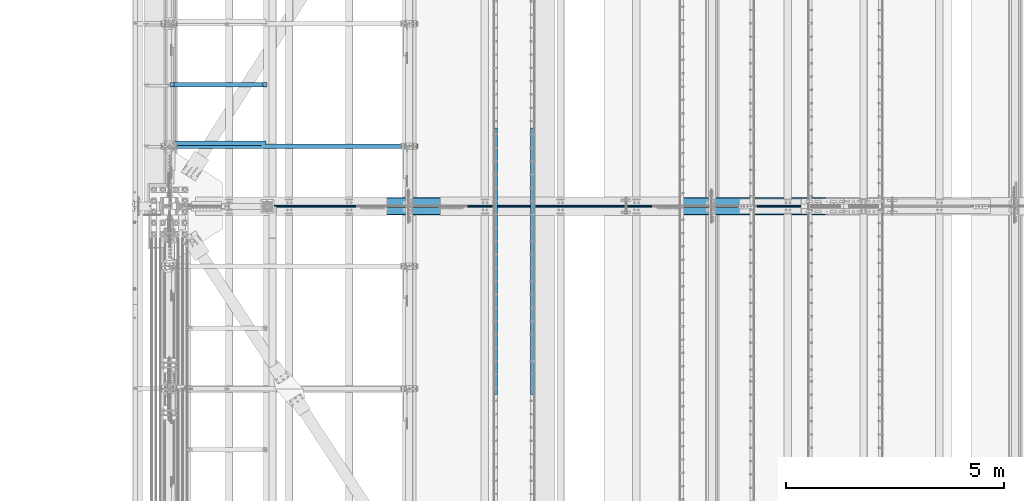
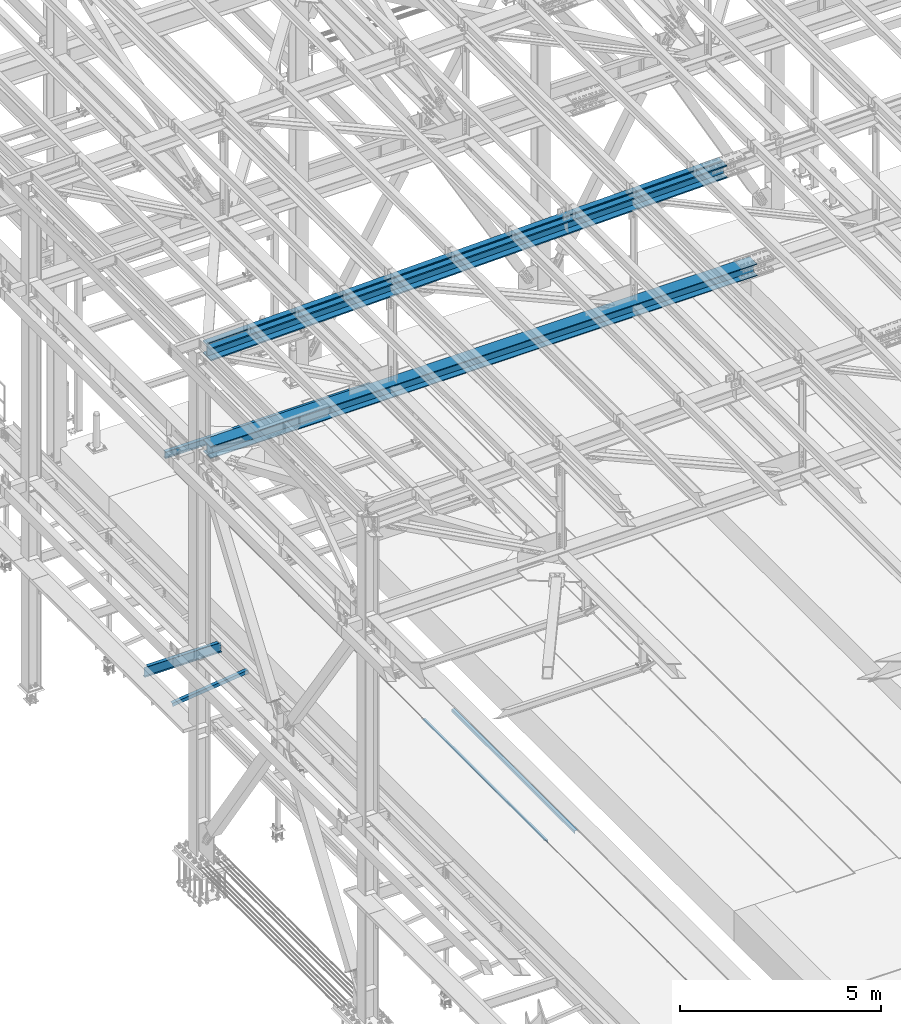
# One storey, part 1874 of 3843: 8 beams, 8 elements without a shape of their own.
"""IFC2X3 building model written with IfcOpenShell, lengths in millimetres."""

from ifc_helpers import new_model, si_unit, frame, origin_with_axes, place, context, subcontext, project, spatial, faceted_brep, material, type_object, element, aggregate, save


model = new_model("IFC2X3")

# Units and contexts
model_context = context("Model", 3, precision=1e-05, world=origin_with_axes())
body_context = subcontext(model_context, "Body", "Model", "MODEL_VIEW")
ifc_project = project(units=[si_unit("LENGTHUNIT", "METRE", prefix="MILLI"), si_unit("AREAUNIT", "SQUARE_METRE"), si_unit("VOLUMEUNIT", "CUBIC_METRE"), si_unit("MASSUNIT", "GRAM", prefix="KILO"), si_unit("TIMEUNIT", "SECOND"), si_unit("PLANEANGLEUNIT", "RADIAN"), si_unit("SOLIDANGLEUNIT", "STERADIAN"), si_unit("THERMODYNAMICTEMPERATUREUNIT", "DEGREE_CELSIUS"), si_unit("LUMINOUSINTENSITYUNIT", "LUMEN")], contexts=[model_context])

# Site, building, storey
site_placement = place(None, origin_with_axes())
site = spatial("IfcSite", under=ifc_project, at=site_placement, CompositionType="ELEMENT")
building_placement = place(site_placement, origin_with_axes())
building = spatial("IfcBuilding", under=site, at=building_placement, Name="Undefined", CompositionType="ELEMENT")
storey_placement = place(building_placement, origin_with_axes())
storey = spatial("IfcBuildingStorey", under=building, at=storey_placement, Name="Undefined", CompositionType="ELEMENT", Elevation=0.0)

# Assembly, beam
assembly_1_placement = place(storey_placement, origin_with_axes())
assembly_1 = element("IfcElementAssembly", 1, at=assembly_1_placement, inside=storey, Name="EMBED_ANGLE", AssemblyPlace="NOTDEFINED", PredefinedType="RIGID_FRAME")
ifc_material_1 = material(Name="STEEL/A36")
beam_type_1 = type_object("IfcBeamType", Name="L3-1/2X3-1/2X5/16", PredefinedType="NOTDEFINED")
beam_1_placement = place(assembly_1_placement, frame((44887.896, 77422.375, 30419.675), z_axis=(0.0, 0.0, -1.0), x_axis=(0.0, -1.0, 0.0)))
beam_1 = element("IfcBeam", 2, at=beam_1_placement, type_object=beam_type_1, material=ifc_material_1, Name="EMBED_ANGLE", ObjectType="L3-1/2X3-1/2X5/16", context=body_context, shape_type="Brep", body=[
    faceted_brep([(-3.63797880709171e-12, 44.4499999999971, -44.4500000000007), (-3.63797880709171e-12, 44.4499999999971, 44.4500000000007), (6096.0, 44.4499999999971, 44.4500000000007), (6096.0, 44.4499999999971, -44.4500000000007), (-3.63797880709171e-12, 36.5124999999971, 44.4500000000007), (6096.0, 36.5124999999971, 44.4500000000007), (-3.63797880709171e-12, 36.5124999999971, -36.5125000000007), (6096.0, 36.5124999999971, -36.5125000000007), (3.63797880709171e-12, -44.4499999999971, -36.5125000000007), (6096.0, -44.4499999999971, -36.5125000000007), (3.63797880709171e-12, -44.4499999999971, -44.4500000000007), (6096.0, -44.4499999999971, -44.4500000000007)], [[[0, 1, 2, 3]], [[1, 4, 5, 2]], [[4, 6, 7, 5]], [[6, 8, 9, 7]], [[8, 10, 11, 9]], [[10, 0, 3, 11]], [[5, 7, 9, 11, 3, 2]], [[10, 8, 6, 4, 1, 0]]]),
])
aggregate(assembly_1, [beam_1])

assembly_2_placement = place(storey_placement, origin_with_axes())
assembly_2 = element("IfcElementAssembly", 3, at=assembly_2_placement, inside=storey, Name="EMBED_ANGLE", AssemblyPlace="NOTDEFINED", PredefinedType="RIGID_FRAME")
beam_2_placement = place(assembly_2_placement, frame((44036.996, 71326.375, 30419.675), z_axis=(0.0, 0.0, -1.0), x_axis=(0.0, 1.0, 0.0)))
beam_2 = element("IfcBeam", 4, at=beam_2_placement, type_object=beam_type_1, material=ifc_material_1, Name="EMBED_ANGLE", ObjectType="L3-1/2X3-1/2X5/16", context=body_context, shape_type="Brep", body=[
    faceted_brep([(-3.63797880709171e-12, 44.4499999999971, -44.4500000000007), (-3.63797880709171e-12, 44.4499999999971, 44.4500000000007), (6096.0, 44.4499999999971, 44.4500000000007), (6096.0, 44.4499999999971, -44.4500000000007), (-3.63797880709171e-12, 36.5124999999971, 44.4500000000007), (6096.0, 36.5124999999971, 44.4500000000007), (-3.63797880709171e-12, 36.5124999999971, -36.5125000000007), (6096.0, 36.5124999999971, -36.5125000000007), (3.63797880709171e-12, -44.4499999999971, -36.5125000000007), (6096.0, -44.4499999999971, -36.5125000000007), (3.63797880709171e-12, -44.4499999999971, -44.4500000000007), (6096.0, -44.4499999999971, -44.4500000000007)], [[[0, 1, 2, 3]], [[1, 4, 5, 2]], [[4, 6, 7, 5]], [[6, 8, 9, 7]], [[8, 10, 11, 9]], [[10, 0, 3, 11]], [[5, 7, 9, 11, 3, 2]], [[10, 8, 6, 4, 1, 0]]]),
])
aggregate(assembly_2, [beam_2])

assembly_3_placement = place(storey_placement, origin_with_axes())
assembly_3 = element("IfcElementAssembly", 5, at=assembly_3_placement, inside=storey, Name="ANGLE", AssemblyPlace="NOTDEFINED", PredefinedType="RIGID_FRAME")
ifc_material_2 = material(Name="STEEL/A572-50")
beam_type_2 = type_object("IfcBeamType", Name="L4X4X3/8", PredefinedType="NOTDEFINED")
beam_3_placement = place(assembly_3_placement, frame((38788.5093206542, 77075.208594, 33960.1419503901), z_axis=(0.0, 1.0, 0.0), x_axis=(-0.993268693078032, 0.0, -0.115833084009098)))
beam_3 = element("IfcBeam", 6, at=beam_3_placement, type_object=beam_type_2, material=ifc_material_2, Name="ANGLE", ObjectType="L4X4X3/8", context=body_context, shape_type="Brep", body=[
    faceted_brep([(0.0, 50.8000000000029, -50.8000000000029), (0.0, 50.8000000000029, 50.8000000000029), (2192.8104802954, 50.7999999940694, 50.8000000000029), (2192.8104802954, 50.7999999940694, -50.8000000000029), (0.0, 41.2750000000015, 50.8000000000029), (2192.81048029537, 41.2749999940788, 50.8000000000029), (0.0, 41.2749999999942, -41.2750000000015), (2192.81048029537, 41.2749999940788, -41.2750000000015), (0.0, -50.8000000000029, -41.2750000000015), (2192.81048029512, -50.8000000058528, -41.2750000000015), (0.0, -50.8000000000029, -50.8000000000029), (2192.81048029512, -50.8000000058528, -50.8000000000029)], [[[0, 1, 2, 3]], [[1, 4, 5, 2]], [[4, 6, 7, 5]], [[6, 8, 9, 7]], [[8, 10, 11, 9]], [[10, 0, 3, 11]], [[5, 7, 9, 11, 3, 2]], [[10, 8, 6, 4, 1, 0]]]),
])
aggregate(assembly_3, [beam_3])

assembly_4_placement = place(storey_placement, origin_with_axes())
assembly_4 = element("IfcElementAssembly", 7, at=assembly_4_placement, inside=storey, Name="dummy", AssemblyPlace="NOTDEFINED", PredefinedType="RIGID_FRAME")
ifc_material_3 = material(Name="STEEL/A992")
beam_type_3 = type_object("IfcBeamType", PredefinedType="NOTDEFINED")
beam_4_placement = place(assembly_4_placement, frame((36788.7250000008, 75628.5, 45423.9652363506), z_axis=(-0.0250987889943571, 0.0, 0.999684975775377), x_axis=(0.999684975775377, 0.0, 0.0250987889943604)))
beam_4 = element("IfcBeam", 8, at=beam_4_placement, type_object=beam_type_3, material=ifc_material_3, Name="dummy", context=body_context, shape_type="Brep", body=[
    faceted_brep([(0.0, -24.6059999999998, 0.0), (0.0, -21.3094210855197, -12.3029999999999), (14796.986409431, -21.3094210855197, -12.3029999777136), (14796.9864094309, -24.6059999999998, 2.22644302994013e-08), (0.0, -12.3029999999999, -21.3094210855197), (14796.986409431, -12.3029999999999, -21.3094210632116), (0.0, 0.0, -24.6059999999998), (14796.986409431, 0.0, -24.6059999776917), (0.0, 12.3029999999999, -21.3094210855197), (14796.986409431, 12.3029999999999, -21.3094210632116), (0.0, 21.3094210855197, -12.3029999999999), (14796.986409431, 21.3094210855197, -12.3029999777136), (0.0, 24.6059999999998, 0.0), (14796.9864094309, 24.6059999999998, 2.22644302994013e-08), (0.0, 21.3094210855197, 12.3029999999999), (14796.9864094309, 21.3094210855197, 12.3030000222425), (0.0, 12.3029999999999, 21.3094210855197), (14796.9864094309, 12.3029999999999, 21.3094211077478), (0.0, 0.0, 24.6059999999998), (14796.9864094309, 0.0, 24.6060000222205), (0.0, -12.3029999999999, 21.3094210855197), (14796.9864094309, -12.3029999999999, 21.3094211077478), (0.0, -21.3094210855197, 12.3029999999999), (14796.9864094309, -21.3094210855197, 12.3030000222425)], [[[0, 1, 2, 3]], [[1, 4, 5, 2]], [[4, 6, 7, 5]], [[6, 8, 9, 7]], [[8, 10, 11, 9]], [[10, 12, 13, 11]], [[12, 14, 15, 13]], [[14, 16, 17, 15]], [[16, 18, 19, 17]], [[18, 20, 21, 19]], [[20, 22, 23, 21]], [[22, 0, 3, 23]], [[5, 7, 9, 11, 13, 15, 17, 19, 21, 23, 3, 2]], [[22, 20, 18, 16, 14, 12, 10, 8, 6, 4, 1, 0]]]),
])
aggregate(assembly_4, [beam_4])

assembly_5_placement = place(storey_placement, origin_with_axes())
assembly_5 = element("IfcElementAssembly", 9, at=assembly_5_placement, inside=storey, Name="BEAM", AssemblyPlace="NOTDEFINED", PredefinedType="RIGID_FRAME")
beam_type_4 = type_object("IfcBeamType", Name="W8X13", PredefinedType="NOTDEFINED")
beam_5_placement = place(assembly_5_placement, frame((36372.8, 77000.1, 41402.0), z_axis=(0.0, 0.0, 1.0), x_axis=(1.0, 0.0, 0.0)))
beam_5 = element("IfcBeam", 10, at=beam_5_placement, type_object=beam_type_4, material=ifc_material_3, Name="BEAM", ObjectType="W8X13", context=body_context, shape_type="Brep", body=[
    faceted_brep([(0.0, 50.7999999999993, -101.599999999999), (0.0, 50.7999999999993, -95.25), (5892.8, 50.7999999999993, -95.25), (5892.8, 50.7999999999993, -101.599999999999), (0.0, 3.17499999999927, -95.25), (5892.8, 3.17499999999927, -95.25), (-2.44140610448085e-05, 3.17500000000291, 95.2499999999927), (5892.8, 3.17499999999927, 95.25), (0.0, 50.7999999999993, 95.25), (5892.8, 50.7999999999993, 95.25), (0.0, 50.7999999999993, 101.599999999999), (5892.8, 50.7999999999993, 101.599999999999), (0.0, -50.7999999999993, 101.599999999999), (5892.8, -50.7999999999993, 101.599999999999), (0.0, -50.7999999999993, 95.25), (5892.8, -50.7999999999993, 95.25), (0.0, -3.17499999999927, 95.25), (5892.8, -3.17499999999927, 95.25), (0.0, -3.17499999999927, -95.25), (5892.8, -3.17499999999927, -95.25), (0.0, -50.7999999999993, -95.25), (5892.8, -50.7999999999993, -95.25), (0.0, -50.7999999999993, -101.599999999999), (5892.8, -50.7999999999993, -101.599999999999)], [[[0, 1, 2, 3]], [[1, 4, 5, 2]], [[4, 6, 7, 5]], [[6, 8, 9, 7]], [[8, 10, 11, 9]], [[10, 12, 13, 11]], [[12, 14, 15, 13]], [[14, 16, 17, 15]], [[16, 18, 19, 17]], [[18, 20, 21, 19]], [[20, 22, 23, 21]], [[22, 0, 3, 23]], [[5, 7, 9, 11, 13, 15, 17, 19, 21, 23, 3, 2]], [[22, 20, 18, 16, 14, 12, 10, 8, 6, 4, 1, 0]]]),
])
aggregate(assembly_5, [beam_5])

assembly_6_placement = place(storey_placement, origin_with_axes())
assembly_6 = element("IfcElementAssembly", 11, at=assembly_6_placement, inside=storey, Name="BEAM", AssemblyPlace="NOTDEFINED", PredefinedType="RIGID_FRAME")
beam_type_5 = type_object("IfcBeamType", Name="W14X193", PredefinedType="NOTDEFINED")
beam_6_placement = place(assembly_6_placement, frame((36581.1928042774, 75628.5, 45221.5968555615), z_axis=(-0.0251104770065213, 0.0, 0.999684682259614), x_axis=(0.99968468698203, 0.0, 0.0251102889995484)))
beam_6 = element("IfcBeam", 12, at=beam_6_placement, type_object=beam_type_5, material=ifc_material_3, Name="BEAM", ObjectType="W14X193", context=body_context, shape_type="Brep", body=[
    faceted_brep([(12012.6310230838, 11.1125000000029, 163.391995248145), (12012.6310230838, 200.024999999994, 163.391995248145), (13514.235091335, 200.024999999994, 162.055596819482), (13514.235091335, 11.1125000000029, 162.055596819482), (10511.0266180469, 11.1125000000029, 164.346565542677), (10511.0266180469, 200.025000000001, 164.346565542677), (9009.42207084113, 11.1125000000029, 164.919307789831), (9009.42207084113, 200.025000000001, 164.919307789831), (7507.81742654402, 11.1125000000029, 165.110221879142), (7507.81742654402, 200.025000000001, 165.110221879142), (6006.21278224691, 11.1125000000029, 164.919307800374), (6006.21278224691, 200.025000000001, 164.919307800374), (4504.60823504109, 11.1125000000029, 164.346565563763), (4504.60823504109, 200.025000000001, 164.346565563763), (3003.00388201789, 11.1125000000029, 163.391995209349), (3003.00388201789, 200.025000000001, 163.391995209349), (1501.39982026855, 11.1125000000029, 162.055596795835), (1501.39982026855, 200.025000000001, 162.055596795835), (211.63116127815, 11.1125000000029, 160.579764938106), (211.63116127815, 200.024999999994, 160.579764938106), (12012.3863993012, 200.024999999994, -157.282911447997), (12012.3863993012, 11.1125000000029, -157.282911447997), (13513.9089263161, 11.1125000000029, -158.619237306542), (13513.9089263161, 200.024999999994, -158.619237306542), (10510.8635355159, 200.025000000001, -156.328392989126), (10510.8635355159, 11.1125000000029, -156.328392989126), (9009.34052957242, 200.025000000001, -155.75568184346), (9009.34052957242, 11.1125000000029, -155.75568184346), (7507.8174265429, 200.025000000001, -155.564778121312), (7507.8174265429, 11.1125000000029, -155.564778121312), (6006.29432351337, 200.025000000001, -155.755681832918), (6006.29432351337, 11.1125000000029, -155.755681832918), (4504.77131756986, 200.025000000001, -156.328392968047), (4504.77131756986, 11.1125000000029, -156.328392968047), (3003.24850579841, 200.025000000001, -157.282911486654), (3003.24850579841, 11.1125000000029, -157.282911486654), (1501.72598528501, 200.025000000001, -158.619237330058), (1501.72598528501, 11.1125000000029, -158.619237330058), (203.576082502259, 200.024999999994, -160.104659517652), (203.576082502259, 11.1125000000029, -160.104659517652), (12012.3585460982, -200.024999999994, -193.795400824296), (12012.3585460982, 200.024999999994, -193.795400824296), (13513.8717887149, 200.024999999994, -195.1317184199), (13513.8717887149, -200.024999999994, -195.1317184199), (10510.8449667129, -200.025000000001, -192.840888267507), (10510.8449667129, 200.025000000001, -192.840888267507), (9009.33124517055, -200.025000000001, -192.268180663086), (9009.33124517055, 200.025000000001, -192.268180663086), (7507.81742654277, -200.025000000001, -192.07727812136), (7507.81742654277, 200.025000000001, -192.07727812136), (6006.303607915, -200.025000000001, -192.268180652551), (6006.303607915, 200.025000000001, -192.268180652551), (4504.78988637264, -200.025000000001, -192.840888246428), (4504.78988637264, 200.025000000001, -192.840888246428), (3003.27635900114, -200.025000000001, -193.795400862931), (3003.27635900114, 200.025000000001, -193.795400862931), (1501.7631228859, -200.025000000001, -195.131718443416), (1501.7631228859, 200.025000000001, -195.131718443416), (202.658920067377, -200.024999999994, -196.618232599249), (202.658920067377, 200.024999999994, -196.618232599249), (12012.3863993012, -11.1125000000029, -157.282911447997), (12012.3863993012, -200.024999999994, -157.282911447997), (13513.9089263161, -200.024999999994, -158.619237306542), (13513.9089263161, -11.1125000000029, -158.619237306542), (10510.8635355159, -11.1125000000029, -156.328392989126), (10510.8635355159, -200.025000000001, -156.328392989126), (9009.34052957242, -11.1125000000029, -155.75568184346), (9009.34052957242, -200.025000000001, -155.75568184346), (7507.8174265429, -11.1125000000029, -155.564778121312), (7507.8174265429, -200.025000000001, -155.564778121312), (6006.29432351337, -11.1125000000029, -155.755681832918), (6006.29432351337, -200.025000000001, -155.755681832918), (4504.77131756986, -11.1125000000029, -156.328392968047), (4504.77131756986, -200.025000000001, -156.328392968047), (3003.24850579841, -11.1125000000029, -157.282911486654), (3003.24850579841, -200.025000000001, -157.282911486654), (1501.72598528501, -11.1125000000029, -158.619237330058), (1501.72598528501, -200.025000000001, -158.619237330058), (203.576082502259, -11.1125000000029, -160.104659517652), (203.576082502259, -200.024999999994, -160.104659517652), (12012.6310230838, -200.024999999994, 163.391995248145), (12012.6310230838, -11.1125000000029, 163.391995248145), (13514.235091335, -11.1125000000029, 162.055596819482), (13514.235091335, -200.024999999994, 162.055596819482), (10511.0266180469, -200.025000000001, 164.346565542677), (10511.0266180469, -11.1125000000029, 164.346565542677), (9009.42207084113, -200.025000000001, 164.919307789831), (9009.42207084113, -11.1125000000029, 164.919307789831), (7507.81742654402, -200.025000000001, 165.110221879142), (7507.81742654402, -11.1125000000029, 165.110221879142), (6006.21278224691, -200.025000000001, 164.919307800374), (6006.21278224691, -11.1125000000029, 164.919307800374), (4504.60823504109, -200.025000000001, 164.346565563763), (4504.60823504109, -11.1125000000029, 164.346565563763), (3003.00388201789, -200.025000000001, 163.391995209349), (3003.00388201789, -11.1125000000029, 163.391995209349), (1501.39982026855, -200.025000000001, 162.055596795835), (1501.39982026855, -11.1125000000029, 162.055596795835), (211.63116127815, -200.024999999994, 160.579764938106), (211.63116127815, -11.1125000000029, 160.579764938106), (212.548323713025, -200.024999999994, 197.093338019702), (212.548323713025, 200.024999999994, 197.093338019702), (1501.36268266766, -200.025000000001, 198.568077909178), (1501.36268266766, 200.025000000001, 198.568077909178), (3002.97602881516, -200.025000000001, 199.904484585633), (3002.97602881516, 200.025000000001, 199.904484585633), (4504.58966623832, -200.025000000001, 200.859060842136), (4504.58966623832, 200.025000000001, 200.859060842136), (6006.20349784529, -200.025000000001, 201.431806620007), (6006.20349784529, 200.025000000001, 201.431806620007), (7507.81742654416, -200.025000000001, 201.622721879205), (7507.81742654416, 200.025000000001, 201.622721879205), (9009.43135524302, -200.025000000001, 201.431806609464), (9009.43135524302, 200.025000000001, 201.431806609464), (10511.04518685, -200.025000000001, 200.859060821043), (10511.04518685, 200.025000000001, 200.859060821043), (12012.6588762868, -200.024999999994, 199.904484624436), (12012.6588762868, 200.024999999994, 199.904484624436), (13514.2722289362, -200.024999999994, 198.56807793284), (13514.2722289362, 200.024999999994, 198.56807793284), (15009.5351971531, -200.024999999994, 196.857106955591), (15009.5351971531, 200.024999999994, 196.857106955591), (15009.4888100907, 200.024999999994, 160.344636426023), (15009.4888100907, 11.1125000000029, 160.344636426023), (15009.0814342832, 11.1125000000029, -160.33010490358), (15009.0814342832, 200.025000000001, -160.33010490358), (15009.0350562786, 200.025000000001, -196.842575443494), (15009.0350562786, -200.025000000001, -196.842575443494), (15009.0814342832, -200.025000000001, -160.33010490358), (15009.0814342832, -11.1125000000029, -160.33010490358), (15009.4888100907, -11.1125000000029, 160.344636426023), (15009.4888100907, -200.024999999994, 160.344636426023)], [[[0, 1, 2, 3]], [[4, 5, 1, 0]], [[6, 7, 5, 4]], [[8, 9, 7, 6]], [[10, 11, 9, 8]], [[12, 13, 11, 10]], [[14, 15, 13, 12]], [[16, 17, 15, 14]], [[17, 16, 18, 19]], [[20, 21, 22, 23]], [[24, 25, 21, 20]], [[26, 27, 25, 24]], [[28, 29, 27, 26]], [[30, 31, 29, 28]], [[32, 33, 31, 30]], [[34, 35, 33, 32]], [[36, 37, 35, 34]], [[37, 36, 38, 39]], [[40, 41, 42, 43]], [[44, 45, 41, 40]], [[46, 47, 45, 44]], [[48, 49, 47, 46]], [[50, 51, 49, 48]], [[52, 53, 51, 50]], [[54, 55, 53, 52]], [[56, 57, 55, 54]], [[57, 56, 58, 59]], [[60, 61, 62, 63]], [[64, 65, 61, 60]], [[66, 67, 65, 64]], [[68, 69, 67, 66]], [[70, 71, 69, 68]], [[72, 73, 71, 70]], [[74, 75, 73, 72]], [[76, 77, 75, 74]], [[77, 76, 78, 79]], [[80, 81, 82, 83]], [[84, 85, 81, 80]], [[86, 87, 85, 84]], [[88, 89, 87, 86]], [[90, 91, 89, 88]], [[92, 93, 91, 90]], [[94, 95, 93, 92]], [[96, 97, 95, 94]], [[97, 96, 98, 99]], [[19, 18, 39, 38, 59, 58, 79, 78, 99, 98, 100, 101]], [[102, 103, 101, 100]], [[103, 102, 104, 105]], [[105, 104, 106, 107]], [[107, 106, 108, 109]], [[109, 108, 110, 111]], [[111, 110, 112, 113]], [[113, 112, 114, 115]], [[115, 114, 116, 117]], [[117, 116, 118, 119]], [[119, 118, 120, 121]], [[2, 1, 5, 7, 9, 11, 13, 15, 17, 19, 101, 103, 105, 107, 109, 111, 113, 115, 117, 119, 121, 122]], [[3, 2, 122, 123]], [[22, 21, 25, 27, 29, 31, 33, 35, 37, 39, 18, 16, 14, 12, 10, 8, 6, 4, 0, 3, 123, 124]], [[23, 22, 124, 125]], [[42, 41, 45, 47, 49, 51, 53, 55, 57, 59, 38, 36, 34, 32, 30, 28, 26, 24, 20, 23, 125, 126]], [[43, 42, 126, 127]], [[62, 61, 65, 67, 69, 71, 73, 75, 77, 79, 58, 56, 54, 52, 50, 48, 46, 44, 40, 43, 127, 128]], [[63, 62, 128, 129]], [[82, 81, 85, 87, 89, 91, 93, 95, 97, 99, 78, 76, 74, 72, 70, 68, 66, 64, 60, 63, 129, 130]], [[83, 82, 130, 131]], [[118, 116, 114, 112, 110, 108, 106, 104, 102, 100, 98, 96, 94, 92, 90, 88, 86, 84, 80, 83, 131, 120]], [[130, 129, 128, 127, 126, 125, 124, 123, 122, 121, 120, 131]]]),
])
aggregate(assembly_6, [beam_6])

assembly_7_placement = place(storey_placement, origin_with_axes())
assembly_7 = element("IfcElementAssembly", 13, at=assembly_7_placement, inside=storey, Name="BEAM", AssemblyPlace="NOTDEFINED", PredefinedType="RIGID_FRAME")
beam_type_6 = type_object("IfcBeamType", Name="W14X120", PredefinedType="NOTDEFINED")
beam_7_placement = place(assembly_7_placement, frame((36575.995336456, 75628.5, 42246.5516278841), z_axis=(-0.00388797399922624, 0.0, 0.999992441800527), x_axis=(0.999992441800527, 0.0, 0.0038879739992243)))
beam_7 = element("IfcBeam", 14, at=beam_7_placement, type_object=beam_type_6, material=ifc_material_3, Name="BEAM", ObjectType="W14X120", context=body_context, shape_type="Brep", body=[
    faceted_brep([(9532.73839779652, -185.737500000003, 165.469169509452), (9532.73839779652, -7.14375000000291, 165.469169509452), (11121.5643632774, -7.14375000000291, 164.827692591709), (11121.5643632774, -185.737500000003, 164.827692591709), (7943.91231720828, -185.737500000003, 165.682995153409), (7943.91231720828, -7.14375000000291, 165.682995153409), (6355.08623662005, -185.737500000003, 165.469169506832), (6355.08623662005, -7.14375000000291, 165.469169506832), (4766.2602711392, -185.737500000003, 164.827692586485), (4766.2602711392, -7.14375000000291, 164.827692586485), (3177.43453587312, -185.737500000003, 163.758564437994), (3177.43453587312, -7.14375000000291, 163.758564437994), (1588.60914592918, -185.737500000003, 162.261785139592), (1588.60914592918, -7.14375000000291, 162.261785139592), (213.479540827058, -185.737500000003, 160.596188706673), (213.479540827058, -7.14375000000291, 160.596188706673), (12710.3900985434, 7.14375000000291, 163.75856444583), (12710.3900985434, 185.737500000003, 163.75856444583), (14299.2154884874, 185.737500000003, 162.261785150054), (14299.2154884874, 7.14375000000291, 162.261785150054), (11121.5643632774, 7.14375000000291, 164.827692591709), (11121.5643632774, 185.737500000003, 164.827692591709), (9532.73839779652, 7.14375000000291, 165.469169509452), (9532.73839779652, 185.737500000003, 165.469169509452), (7943.91231720828, 7.14375000000291, 165.682995153409), (7943.91231720828, 185.737500000003, 165.682995153409), (6355.08623662005, 7.14375000000291, 165.469169506832), (6355.08623662005, 185.737500000003, 165.469169506832), (4766.2602711392, 7.14375000000291, 164.827692586485), (4766.2602711392, 185.737500000003, 164.827692586485), (3177.43453587312, 7.14375000000291, 163.758564437994), (3177.43453587312, 185.737500000003, 163.758564437994), (1588.60914592918, 7.14375000000291, 162.261785139592), (1588.60914592918, 185.737500000003, 162.261785139592), (213.479540827058, 7.14375000000291, 160.596188706673), (213.479540827058, 185.737500000003, 160.596188706673), (12710.1311581915, 185.737500000003, -156.916331009219), (12710.1311581915, 7.14375000000291, -156.916331009219), (14298.8702347139, 7.14375000000291, -158.413028992014), (14298.8702347139, 185.737500000003, -158.413028992014), (11121.3917363657, 185.737500000003, -155.847260944051), (11121.3917363657, 7.14375000000291, -155.847260944051), (9532.65208433771, 185.737500000003, -155.205818874747), (9532.65208433771, 7.14375000000291, -155.205818874747), (7943.91231720855, 185.737500000003, -154.992004846928), (7943.91231720855, 7.14375000000291, -154.992004846928), (6355.17255007938, 185.737500000003, -155.205818877366), (6355.17255007938, 7.14375000000291, -155.205818877366), (4766.43289805136, 185.737500000003, -155.847260949289), (4766.43289805136, 7.14375000000291, -155.847260949289), (3177.69347622558, 185.737500000003, -156.91633101707), (3177.69347622558, 7.14375000000291, -156.91633101707), (1588.95439970319, 185.737500000003, -158.41302900247), (1588.95439970319, 7.14375000000291, -158.41302900247), (213.900240854979, 185.737500000003, -160.078534052729), (213.900240854979, 7.14375000000291, -160.078534052729), (12710.1119299476, -185.737500000003, -180.728823245983), (12710.1119299476, 185.737500000003, -180.728823245983), (14298.8445970575, 185.737500000003, -182.225515190672), (14298.8445970575, -185.737500000003, -182.225515190672), (11121.3789175357, -185.737500000003, -179.65975749374), (11121.3789175357, 185.737500000003, -179.65975749374), (9532.64567492246, -185.737500000003, -179.018318012182), (9532.64567492246, 185.737500000003, -179.018318012182), (7943.91231720857, -185.737500000003, -178.804504846958), (7943.91231720857, 185.737500000003, -178.804504846958), (6355.17895949468, -185.737500000003, -179.018318014801), (6355.17895949468, 185.737500000003, -179.018318014801), (4766.44571688146, -185.737500000003, -179.659757498965), (4766.44571688146, 185.737500000003, -179.659757498965), (3177.71270446959, -185.737500000003, -180.728823253827), (3177.71270446959, 185.737500000003, -180.728823253827), (1588.98003735969, -185.737500000003, -182.225515201142), (1588.98003735969, 185.737500000003, -182.225515201142), (213.93148095606, -185.737500000003, -183.891013465553), (213.93148095606, 185.737500000003, -183.891013465553), (12710.1311581915, -7.14375000000291, -156.916331009219), (12710.1311581915, -185.737500000003, -156.916331009219), (14298.8702347139, -185.737500000003, -158.413028992014), (14298.8702347139, -7.14375000000291, -158.413028992014), (11121.3917363657, -7.14375000000291, -155.847260944051), (11121.3917363657, -185.737500000003, -155.847260944051), (9532.65208433771, -7.14375000000291, -155.205818874747), (9532.65208433771, -185.737500000003, -155.205818874747), (7943.91231720855, -7.14375000000291, -154.992004846928), (7943.91231720855, -185.737500000003, -154.992004846928), (6355.17255007938, -7.14375000000291, -155.205818877366), (6355.17255007938, -185.737500000003, -155.205818877366), (4766.43289805136, -7.14375000000291, -155.847260949289), (4766.43289805136, -185.737500000003, -155.847260949289), (3177.69347622558, -7.14375000000291, -156.91633101707), (3177.69347622558, -185.737500000003, -156.91633101707), (1588.95439970319, -7.14375000000291, -158.41302900247), (1588.95439970319, -185.737500000003, -158.41302900247), (213.900240854979, -7.14375000000291, -160.078534052729), (213.900240854979, -185.737500000003, -160.078534052729), (213.448300725977, -185.737500000003, 184.408668119504), (213.448300725977, 185.737500000003, 184.408668119504), (1588.5835082727, -185.737500000003, 186.074271338264), (1588.5835082727, 185.737500000003, 186.074271338264), (3177.41530762913, -185.737500000003, 187.571056674751), (3177.41530762913, 185.737500000003, 187.571056674751), (4766.24745230909, -185.737500000003, 188.640189136167), (4766.24745230909, 185.737500000003, 188.640189136167), (6355.07982720475, -185.737500000003, 189.281668644275), (6355.07982720475, 185.737500000003, 189.281668644275), (7943.91231720826, -185.737500000003, 189.495495153438), (7943.91231720826, 185.737500000003, 189.495495153438), (9532.74480721178, -185.737500000003, 189.281668646887), (9532.74480721178, 185.737500000003, 189.281668646887), (11121.5771821074, -185.737500000003, 188.640189141399), (11121.5771821074, 185.737500000003, 188.640189141399), (12710.4093267874, -185.737500000003, 187.571056682595), (12710.4093267874, 185.737500000003, 187.571056682595), (14299.2411261438, -185.737500000003, 186.074271348727), (14299.2411261438, 185.737500000003, 186.074271348727), (15881.7223570669, -185.737500000003, 184.157524679875), (15881.7223570669, 185.737500000003, 184.157524679875), (15881.6903245479, 185.737500000003, 160.345046226852), (15881.6903245479, 7.14375000000291, 160.345046226852), (15881.2589532919, 7.14375000000291, -160.329663607248), (15881.2589532919, 185.737500000003, -160.329663607248), (15881.2269207729, 185.737500000003, -184.142142060278), (15881.2269207729, -185.737500000003, -184.142142060278), (15881.2589532919, -185.737500000003, -160.329663607248), (15881.2589532919, -7.14375000000291, -160.329663607248), (14299.2154884874, -7.14375000000291, 162.261785150054), (12710.3900985434, -7.14375000000291, 163.75856444583), (15881.6903245479, -7.14375000000291, 160.345046226852), (12710.3900985434, -185.737500000003, 163.75856444583), (14299.2154884874, -185.737500000003, 162.261785150054), (15881.6903245479, -185.737500000003, 160.345046226852)], [[[0, 1, 2, 3]], [[4, 5, 1, 0]], [[6, 7, 5, 4]], [[8, 9, 7, 6]], [[10, 11, 9, 8]], [[12, 13, 11, 10]], [[13, 12, 14, 15]], [[16, 17, 18, 19]], [[20, 21, 17, 16]], [[22, 23, 21, 20]], [[24, 25, 23, 22]], [[26, 27, 25, 24]], [[28, 29, 27, 26]], [[30, 31, 29, 28]], [[32, 33, 31, 30]], [[33, 32, 34, 35]], [[36, 37, 38, 39]], [[40, 41, 37, 36]], [[42, 43, 41, 40]], [[44, 45, 43, 42]], [[46, 47, 45, 44]], [[48, 49, 47, 46]], [[50, 51, 49, 48]], [[52, 53, 51, 50]], [[53, 52, 54, 55]], [[56, 57, 58, 59]], [[60, 61, 57, 56]], [[62, 63, 61, 60]], [[64, 65, 63, 62]], [[66, 67, 65, 64]], [[68, 69, 67, 66]], [[70, 71, 69, 68]], [[72, 73, 71, 70]], [[73, 72, 74, 75]], [[76, 77, 78, 79]], [[80, 81, 77, 76]], [[82, 83, 81, 80]], [[84, 85, 83, 82]], [[86, 87, 85, 84]], [[88, 89, 87, 86]], [[90, 91, 89, 88]], [[92, 93, 91, 90]], [[93, 92, 94, 95]], [[15, 14, 96, 97, 35, 34, 55, 54, 75, 74, 95, 94]], [[98, 99, 97, 96]], [[99, 98, 100, 101]], [[101, 100, 102, 103]], [[103, 102, 104, 105]], [[105, 104, 106, 107]], [[107, 106, 108, 109]], [[109, 108, 110, 111]], [[111, 110, 112, 113]], [[113, 112, 114, 115]], [[115, 114, 116, 117]], [[18, 17, 21, 23, 25, 27, 29, 31, 33, 35, 97, 99, 101, 103, 105, 107, 109, 111, 113, 115, 117, 118]], [[19, 18, 118, 119]], [[38, 37, 41, 43, 45, 47, 49, 51, 53, 55, 34, 32, 30, 28, 26, 24, 22, 20, 16, 19, 119, 120]], [[39, 38, 120, 121]], [[58, 57, 61, 63, 65, 67, 69, 71, 73, 75, 54, 52, 50, 48, 46, 44, 42, 40, 36, 39, 121, 122]], [[59, 58, 122, 123]], [[78, 77, 81, 83, 85, 87, 89, 91, 93, 95, 74, 72, 70, 68, 66, 64, 62, 60, 56, 59, 123, 124]], [[79, 78, 124, 125]], [[126, 127, 2, 1, 5, 7, 9, 11, 13, 15, 94, 92, 90, 88, 86, 84, 82, 80, 76, 79, 125, 128]], [[3, 2, 127, 129]], [[114, 112, 110, 108, 106, 104, 102, 100, 98, 96, 14, 12, 10, 8, 6, 4, 0, 3, 129, 130, 131, 116]], [[128, 125, 124, 123, 122, 121, 120, 119, 118, 117, 116, 131]], [[130, 126, 128, 131]], [[129, 127, 126, 130]]]),
])
aggregate(assembly_7, [beam_7])

assembly_8_placement = place(storey_placement, origin_with_axes())
assembly_8 = element("IfcElementAssembly", 15, at=assembly_8_placement, inside=storey, Name="BEAM", AssemblyPlace="NOTDEFINED", PredefinedType="RIGID_FRAME")
beam_type_7 = type_object("IfcBeamType", Name="W12X14", PredefinedType="NOTDEFINED")
beam_8_placement = place(assembly_8_placement, frame((36576.0, 78413.967188, 33885.1875), z_axis=(0.0, 0.0, 1.0), x_axis=(1.0, 0.0, 0.0)))
beam_8 = element("IfcBeam", 16, at=beam_8_placement, type_object=beam_type_7, material=ifc_material_3, Name="BEAM", ObjectType="W12X14", context=body_context, shape_type="Brep", body=[
    faceted_brep([(92.8687501907334, -2.38125000000582, 125.412499999991), (92.8687501907334, 2.38125000000582, 125.412499999991), (16.6687499999971, 2.38125000000582, 125.412499999991), (16.6687499999971, -2.38125000000582, 125.412499999991), (97.7288297087798, -2.38125000000582, 126.379229922582), (97.7288297087798, 2.38125000000582, 126.379229922582), (101.849006176933, -2.38125000000582, 129.132243823056), (101.849006176933, 2.38125000000582, 129.132243823056), (104.602020077407, -2.38125000000582, 133.25242029121), (104.602020077407, 2.38125000000582, 133.25242029121), (105.568749999999, -2.38125000000582, 138.112499809256), (105.568749999999, 2.38125000000582, 138.112499809256), (105.568749999999, -50.8000000000029, 150.812499810811), (105.568749999999, 50.8000000000029, 150.8125), (105.568749999999, 50.8000000000029, 144.462500000001), (105.568749999999, 2.38125000000582, 144.462500000001), (105.568749999999, -2.38125000000582, 144.462500000001), (105.568749999999, -50.8000000000029, 144.462500000001), (16.6687499999971, -2.38125000000582, -144.462500000001), (16.6687499999971, -50.7999999999993, -144.462500000001), (2228.05625, -50.8000000000029, -144.462500000001), (2228.05625, -2.38125000000582, -144.462500000001), (16.6687499999971, -50.8000000000029, -150.8125), (2228.05625, -50.8000000000029, -150.8125), (16.6687499999971, 50.8000000000029, -150.8125), (2228.05625, 50.8000000000029, -150.8125), (16.6687499999971, 50.7999999999993, -144.462500000001), (2228.05625, 50.8000000000029, -144.462500000001), (16.6687499999971, 2.38125000000582, -144.462500000001), (2228.05625, 2.38125000000582, -144.462500000001), (2228.05625, 2.38125000000582, -117.887499999997), (2228.05625, 2.38125000000582, 112.712500000001), (2228.05625, 2.38125000000582, 125.412499999991), (2228.05625, -2.38125000000582, 125.412499999991), (2151.85624980927, 2.38125000000582, 125.412499999991), (2151.85624980927, -2.38125000000582, 125.412499999991), (2146.99617029122, 2.38125000000582, 126.379229922582), (2146.99617029122, -2.38125000000582, 126.379229922582), (2142.87599382307, 2.38125000000582, 129.132243823056), (2142.87599382307, -2.38125000000582, 129.132243823056), (2140.12297992259, 2.38125000000582, 133.25242029121), (2140.12297992259, -2.38125000000582, 133.25242029121), (2139.15625, 2.38125000000582, 138.112499809256), (2139.15625, -2.38125000000582, 138.112499809256), (2139.15625, -50.8000000000029, 150.8125), (2139.15625, -50.8000000000029, 144.462500000001), (2139.15625, -2.38125000000582, 144.462500000001), (2139.15625, 2.38125000000582, 144.462500000001), (2139.15625, 50.8000000000029, 144.462500000001), (2139.15625, 50.8000000000029, 150.8125), (16.6687499999971, 2.38125000000582, 112.712500000001), (16.6687499999971, 2.38125000000582, -117.887499999997)], [[[0, 1, 2, 3]], [[4, 5, 1, 0]], [[6, 7, 5, 4]], [[8, 9, 7, 6]], [[10, 11, 9, 8]], [[12, 13, 14, 15, 11, 10, 16, 17]], [[18, 19, 20, 21]], [[19, 22, 23, 20]], [[22, 24, 25, 23]], [[24, 26, 27, 25]], [[26, 28, 29, 27]], [[21, 20, 23, 25, 27, 29, 30, 31, 32, 33]], [[33, 32, 34, 35]], [[35, 34, 36, 37]], [[37, 36, 38, 39]], [[39, 38, 40, 41]], [[41, 40, 42, 43]], [[44, 45, 46, 43, 42, 47, 48, 49]], [[45, 44, 12, 17]], [[46, 45, 17, 16]], [[8, 6, 4, 0, 3, 18, 21, 33, 35, 37, 39, 41, 43, 46, 16, 10]], [[50, 51, 28, 26, 24, 22, 19, 18, 3, 2]], [[47, 42, 40, 38, 36, 34, 32, 31, 30, 29, 28, 51, 50, 2, 1, 5, 7, 9, 11, 15]], [[48, 47, 15, 14]], [[49, 48, 14, 13]], [[44, 49, 13, 12]]]),
])
aggregate(assembly_8, [beam_8])

save(model, "model.ifc")
